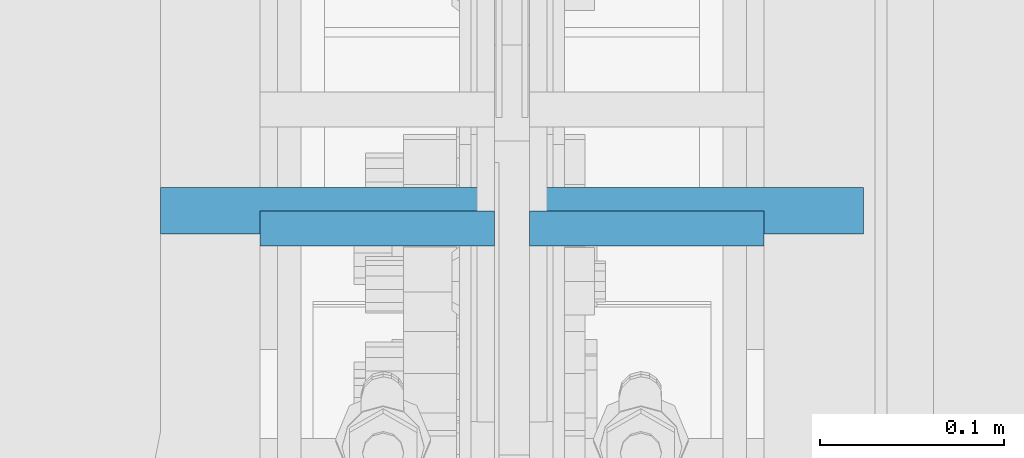
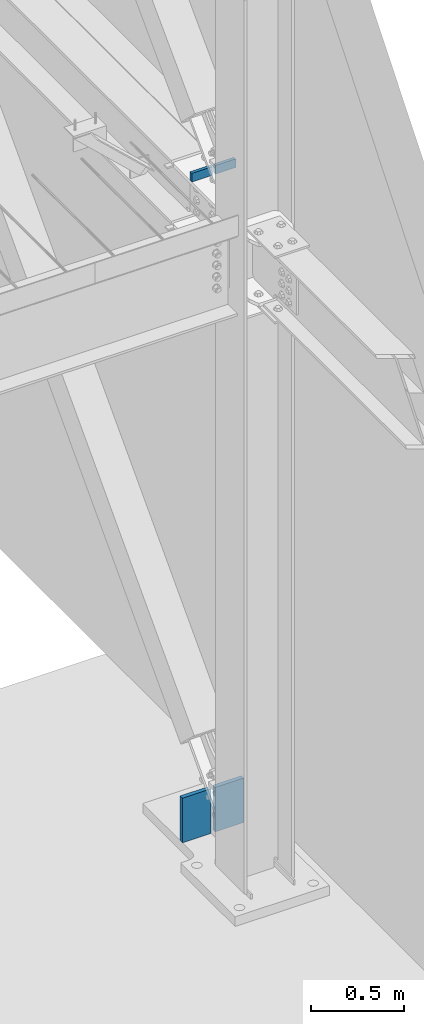
# One storey, part 408 of 1179: 4 columns, 3 elements without a shape of their own.
"""IFC2X3 building model written with IfcOpenShell, lengths in millimetres."""

from ifc_helpers import new_model, si_unit, frame, origin_with_axes, place, context, subcontext, project, spatial, faceted_brep, material, type_object, element, aggregate, save


model = new_model("IFC2X3")

# Units and contexts
model_context = context("Model", 3, precision=1e-05, world=origin_with_axes())
body_context = subcontext(model_context, "Body", "Model", "MODEL_VIEW")
ifc_project = project(units=[si_unit("LENGTHUNIT", "METRE", prefix="MILLI"), si_unit("AREAUNIT", "SQUARE_METRE"), si_unit("VOLUMEUNIT", "CUBIC_METRE"), si_unit("MASSUNIT", "GRAM", prefix="KILO"), si_unit("TIMEUNIT", "SECOND"), si_unit("PLANEANGLEUNIT", "RADIAN"), si_unit("SOLIDANGLEUNIT", "STERADIAN"), si_unit("THERMODYNAMICTEMPERATUREUNIT", "DEGREE_CELSIUS"), si_unit("LUMINOUSINTENSITYUNIT", "LUMEN")], contexts=[model_context])

# Site, building, storey
site_placement = place(None, origin_with_axes())
site = spatial("IfcSite", under=ifc_project, at=site_placement, CompositionType="ELEMENT")
building_placement = place(site_placement, origin_with_axes())
building = spatial("IfcBuilding", under=site, at=building_placement, Name="Undefined", CompositionType="ELEMENT")
storey_placement = place(building_placement, origin_with_axes())
storey = spatial("IfcBuildingStorey", under=building, at=storey_placement, Name="Undefined", CompositionType="ELEMENT", Elevation=0.0)

# Assembly, column
assembly_1_placement = place(storey_placement, origin_with_axes())
assembly_1 = element("IfcElementAssembly", 1, at=assembly_1_placement, inside=storey, Name="PLATE", AssemblyPlace="NOTDEFINED", PredefinedType="RIGID_FRAME")
ifc_material = material(Name="STEEL/A572-GR.50")
column_type_1 = type_object("IfcColumnType", PredefinedType="NOTDEFINED")
column_1_placement = place(assembly_1_placement, frame((24206.2, 11943.2331124363, -215.9), z_axis=(1.0, 0.0, 0.0), x_axis=(0.0, 0.0, 1.0)))
column_1 = element("IfcColumn", 2, at=column_1_placement, type_object=column_type_1, material=ifc_material, Name="PLATE", context=body_context, shape_type="Brep", body=[
    faceted_brep([(0.0, 12.6999999999998, -88.9000000000015), (0.0, 12.6999999999998, 88.9000000000015), (292.287947617165, 12.7000000000007, 88.9000000000015), (292.287947617165, 12.7000000000007, -88.9000000000015), (0.0, -12.6999999999998, 88.9000000000015), (292.287947617165, -12.7000000000007, 88.9000000000015), (0.0, -12.6999999999998, -88.9000000000015), (292.287947617165, -12.7000000000007, -88.9000000000015)], [[[0, 1, 2, 3]], [[1, 4, 5, 2]], [[4, 6, 7, 5]], [[6, 0, 3, 7]], [[5, 7, 3, 2]], [[6, 4, 1, 0]]]),
])
aggregate(assembly_1, [column_1])

assembly_2_placement = place(storey_placement, origin_with_axes())
assembly_2 = element("IfcElementAssembly", 3, at=assembly_2_placement, inside=storey, Name="PLATE", AssemblyPlace="NOTDEFINED", PredefinedType="RIGID_FRAME")
column_2_placement = place(assembly_2_placement, frame((24409.4, 11943.2331124363, -215.9), z_axis=(-1.0, 0.0, 0.0), x_axis=(0.0, 0.0, 1.0)))
column_2 = element("IfcColumn", 4, at=column_2_placement, type_object=column_type_1, material=ifc_material, Name="PLATE", context=body_context, shape_type="Brep", body=[
    faceted_brep([(0.0, 12.6999999999998, -88.9000000000015), (0.0, 12.6999999999998, 88.9000000000015), (292.287947617165, 12.7000000000007, 88.9000000000015), (292.287947617165, 12.7000000000007, -88.9000000000015), (0.0, -12.6999999999998, 88.9000000000015), (292.287947617165, -12.7000000000007, 88.9000000000015), (0.0, -12.6999999999998, -88.9000000000015), (292.287947617165, -12.7000000000007, -88.9000000000015)], [[[0, 1, 2, 3]], [[1, 4, 5, 2]], [[4, 6, 7, 5]], [[6, 0, 3, 7]], [[5, 7, 3, 2]], [[6, 4, 1, 0]]]),
])
aggregate(assembly_2, [column_2])

# Assembly, columns
assembly_3_placement = place(storey_placement, origin_with_axes())
assembly_3 = element("IfcElementAssembly", 5, at=assembly_3_placement, inside=storey, Name="COLUMN", AssemblyPlace="NOTDEFINED", PredefinedType="RIGID_FRAME")
column_type_2 = type_object("IfcColumnType", PredefinedType="NOTDEFINED")
column_3_placement = place(assembly_3_placement, frame((24234.775, 11933.5734303229, 4102.1), z_axis=(1.0, 0.0, 0.0), x_axis=(0.0, 0.0, 1.0)))
column_3 = element("IfcColumn", 6, at=column_3_placement, type_object=column_type_2, material=ifc_material, Name="PLATE", context=body_context, shape_type="Brep", body=[
    faceted_brep([(0.0, 9.52500000000146, -63.5), (0.0, 9.52500000000146, 63.5), (56.4906928705395, 9.52499999999964, 63.5), (56.4906928705395, 9.52499999999964, -63.5), (0.0, -9.52500000000146, 63.5), (56.4906928705395, -9.52499999999964, 63.5), (0.0, -9.52500000000146, -63.5), (56.4906928705395, -9.52499999999964, -63.5)], [[[0, 1, 2, 3]], [[1, 4, 5, 2]], [[4, 6, 7, 5]], [[6, 0, 3, 7]], [[5, 7, 3, 2]], [[6, 4, 1, 0]]]),
])
column_4_placement = place(assembly_3_placement, frame((24380.825, 11933.5734303229, 4102.1), z_axis=(-1.0, 0.0, 0.0), x_axis=(0.0, 0.0, 1.0)))
column_4 = element("IfcColumn", 7, at=column_4_placement, type_object=column_type_2, material=ifc_material, Name="PLATE", context=body_context, shape_type="Brep", body=[
    faceted_brep([(0.0, 9.52500000000146, -63.5), (0.0, 9.52500000000146, 63.5), (56.4906928705395, 9.52499999999964, 63.5), (56.4906928705395, 9.52499999999964, -63.5), (0.0, -9.52500000000146, 63.5), (56.4906928705395, -9.52499999999964, 63.5), (0.0, -9.52500000000146, -63.5), (56.4906928705395, -9.52499999999964, -63.5)], [[[0, 1, 2, 3]], [[1, 4, 5, 2]], [[4, 6, 7, 5]], [[6, 0, 3, 7]], [[5, 7, 3, 2]], [[6, 4, 1, 0]]]),
])
aggregate(assembly_3, [column_3, column_4])

save(model, "model.ifc")
